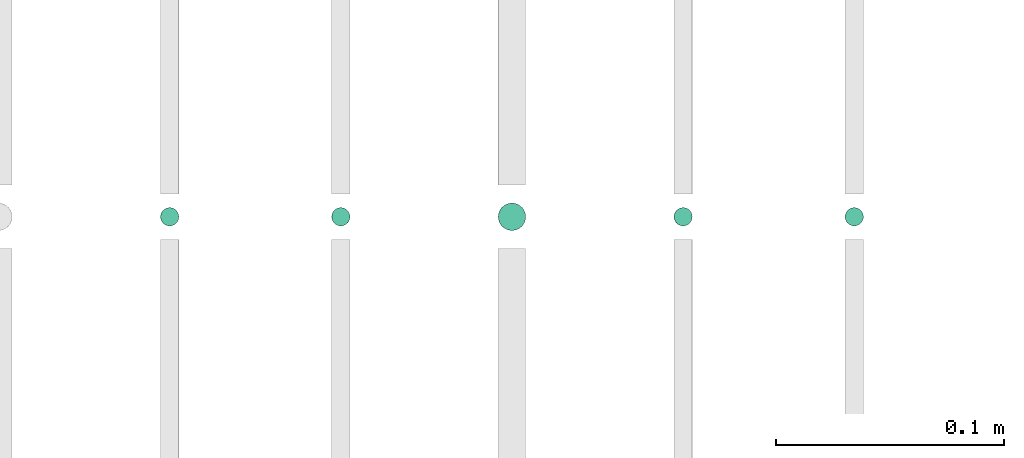
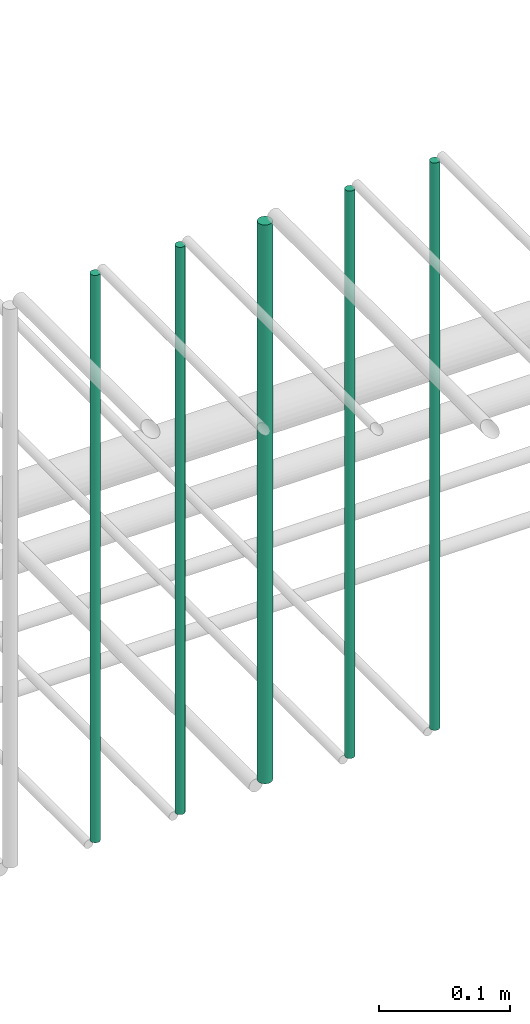
# One storey, part 177 of 331: 5 flow segments.
"""IFC2X3 building model written with IfcOpenShell, lengths in millimetres."""

from ifc_helpers import new_model, entity, si_unit, converted_unit, derived_unit, direction, frame, frame_2d, origin, origin_2d_with_axis, place, context, subcontext, project, spatial, circle, extrude, type_object, element, save


model = new_model("IFC2X3")

# Units and contexts
model_context = context("Model", 3, precision=0.01, world=origin(), true_north=direction((6.12303176911189e-17, 1.0)))
body_context = subcontext(model_context, "Body", "Model", "MODEL_VIEW")
ifc_project = project(units=[si_unit("LENGTHUNIT", "METRE", prefix="MILLI"), si_unit("AREAUNIT", "SQUARE_METRE"), si_unit("VOLUMEUNIT", "CUBIC_METRE"), converted_unit("PLANEANGLEUNIT", "DEGREE", entity("IfcRatioMeasure", 0.0174532925199433), si_unit("PLANEANGLEUNIT", "RADIAN"), dimensions=[0, 0, 0, 0, 0, 0, 0]), si_unit("MASSUNIT", "GRAM", prefix="KILO"), derived_unit("MASSDENSITYUNIT", [(si_unit("MASSUNIT", "GRAM", prefix="KILO"), 1), (si_unit("LENGTHUNIT", "METRE"), -3)]), derived_unit("MOMENTOFINERTIAUNIT", [(si_unit("LENGTHUNIT", "METRE"), 4)]), si_unit("TIMEUNIT", "SECOND"), si_unit("FREQUENCYUNIT", "HERTZ"), si_unit("THERMODYNAMICTEMPERATUREUNIT", "DEGREE_CELSIUS"), derived_unit("THERMALTRANSMITTANCEUNIT", [(si_unit("MASSUNIT", "GRAM", prefix="KILO"), 1), (si_unit("THERMODYNAMICTEMPERATUREUNIT", "KELVIN"), -1), (si_unit("TIMEUNIT", "SECOND"), -3)]), derived_unit("VOLUMETRICFLOWRATEUNIT", [(si_unit("LENGTHUNIT", "METRE"), 3), (si_unit("TIMEUNIT", "SECOND"), -1)]), derived_unit("MASSFLOWRATEUNIT", [(si_unit("MASSUNIT", "GRAM", prefix="KILO"), 1), (si_unit("TIMEUNIT", "SECOND"), -1)]), derived_unit("ROTATIONALFREQUENCYUNIT", [(si_unit("TIMEUNIT", "SECOND"), -1)]), si_unit("ELECTRICCURRENTUNIT", "AMPERE"), si_unit("ELECTRICVOLTAGEUNIT", "VOLT"), si_unit("POWERUNIT", "WATT"), si_unit("FORCEUNIT", "NEWTON", prefix="KILO"), si_unit("ILLUMINANCEUNIT", "LUX"), si_unit("LUMINOUSFLUXUNIT", "LUMEN"), si_unit("LUMINOUSINTENSITYUNIT", "CANDELA"), derived_unit("USERDEFINED", [(si_unit("MASSUNIT", "GRAM", prefix="KILO"), -1), (si_unit("LENGTHUNIT", "METRE"), -2), (si_unit("TIMEUNIT", "SECOND"), 3), (si_unit("LUMINOUSFLUXUNIT", "LUMEN"), 1)]), derived_unit("LINEARVELOCITYUNIT", [(si_unit("LENGTHUNIT", "METRE"), 1), (si_unit("TIMEUNIT", "SECOND"), -1)]), si_unit("PRESSUREUNIT", "PASCAL"), derived_unit("USERDEFINED", [(si_unit("LENGTHUNIT", "METRE"), -2), (si_unit("MASSUNIT", "GRAM", prefix="KILO"), 1), (si_unit("TIMEUNIT", "SECOND"), -2)]), derived_unit("LINEARFORCEUNIT", [(si_unit("MASSUNIT", "GRAM", prefix="KILO"), 1), (si_unit("LENGTHUNIT", "METRE"), 1), (si_unit("TIMEUNIT", "SECOND"), -2), (si_unit("LENGTHUNIT", "METRE"), -1)]), derived_unit("PLANARFORCEUNIT", [(si_unit("MASSUNIT", "GRAM", prefix="KILO"), 1), (si_unit("LENGTHUNIT", "METRE"), 1), (si_unit("TIMEUNIT", "SECOND"), -2), (si_unit("LENGTHUNIT", "METRE"), -2)])], contexts=[model_context])

# Site, building, storey
site_placement = place(None, frame((0.0, -0.00077364408347762, 0.0)))
site = spatial("IfcSite", under=ifc_project, at=site_placement, CompositionType="ELEMENT")
building_placement = place(site_placement, origin())
building = spatial("IfcBuilding", under=site, at=building_placement, CompositionType="ELEMENT")
storey_placement = place(building_placement, origin())
storey = spatial("IfcBuildingStorey", under=building, at=storey_placement, CompositionType="ELEMENT", Elevation=0.0)

# Flow segments
pipe_segment_type = type_object("IfcPipeSegmentType", PredefinedType="NOTDEFINED")
flow_segment_1_placement = place(storey_placement, frame((44864.6371022652, 5638.02529159143, 14560.0)))
element("IfcFlowSegment", 1, at=flow_segment_1_placement, inside=storey, type_object=pipe_segment_type, context=body_context, shape_type="SweptSolid", body=[
    extrude(circle(Radius=4.0, at=origin_2d_with_axis()), frame((5.59527223591499, 5.59527223591607, 0.0), z_axis=(0.0, 0.0, 1.0), x_axis=(-1.0, 0.0, 0.0)), (0.0, 0.0, 1.0), 530.000000000018),
])
flow_segment_2_placement = place(storey_placement, frame((44789.6371022652, 5638.02529159143, 14560.0)))
element("IfcFlowSegment", 2, at=flow_segment_2_placement, inside=storey, type_object=pipe_segment_type, context=body_context, shape_type="SweptSolid", body=[
    extrude(circle(Radius=4.0, at=origin_2d_with_axis()), frame((5.59527223591499, 5.59527223591607, 0.0), z_axis=(0.0, 0.0, 1.0), x_axis=(-1.0, 0.0, 0.0)), (0.0, 0.0, 1.0), 530.000000000001),
])
flow_segment_3_placement = place(storey_placement, frame((44712.6371022652, 5636.02529159143, 14564.0)))
element("IfcFlowSegment", 3, at=flow_segment_3_placement, inside=storey, type_object=pipe_segment_type, context=body_context, shape_type="SweptSolid", body=[
    extrude(circle(Radius=6.0, at=origin_2d_with_axis()), frame((7.59527223591454, 7.59527223591562, 0.0), z_axis=(0.0, 0.0, 1.0), x_axis=(-1.0, 0.0, 0.0)), (0.0, 0.0, 1.0), 521.999999999992),
])
flow_segment_4_placement = place(storey_placement, frame((44639.6371022652, 5638.02529159143, 14560.0)))
element("IfcFlowSegment", 4, at=flow_segment_4_placement, inside=storey, type_object=pipe_segment_type, context=body_context, shape_type="SweptSolid", body=[
    extrude(circle(Radius=4.0, at=origin_2d_with_axis()), frame((5.59527223591499, 5.59527223591607, 0.0), z_axis=(0.0, 0.0, 1.0), x_axis=(-1.0, 0.0, 0.0)), (0.0, 0.0, 1.0), 530.000000000009),
])
flow_segment_5_placement = place(storey_placement, frame((44564.6371022652, 5638.02529159144, 14560.0)))
element("IfcFlowSegment", 5, at=flow_segment_5_placement, inside=storey, type_object=pipe_segment_type, context=body_context, shape_type="SweptSolid", body=[
    extrude(circle(Radius=4.0, at=frame_2d((0.0, -1.08286712929839e-12), x_axis=(1.0, 0.0))), frame((5.59527223591499, 5.59527223591499, 0.0), z_axis=(0.0, 0.0, 1.0), x_axis=(-1.0, 0.0, 0.0)), (0.0, 0.0, 1.0), 529.999996142993),
])

save(model, "model.ifc")
